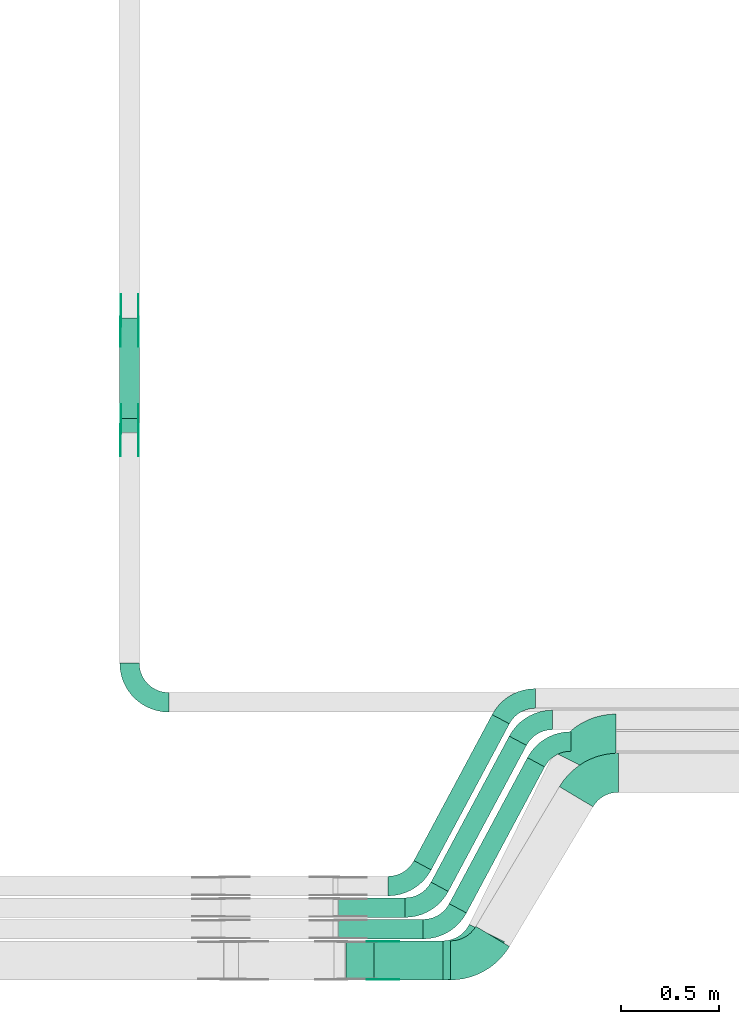
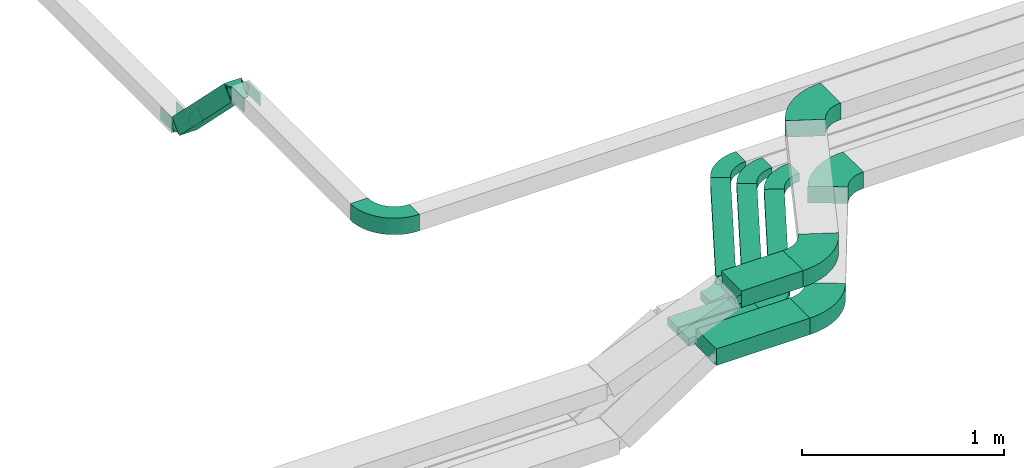
# One storey, part 8 of 25: 21 flow fittings, 8 flow segments.
"""IFC2X3 building model written with IfcOpenShell, lengths in millimetres."""

from ifc_helpers import new_model, entity, si_unit, converted_unit, derived_unit, direction, frame, frame_2d, origin, origin_2d_with_axis, place, context, subcontext, project, spatial, polyline, circle_curve, parameter, trimmed, segment, composite_curve, rectangle, outline, extrude, source, transform, mapped, material, type_object, type_shapes, element, save


model = new_model("IFC2X3")

# Units and contexts
model_context = context("Model", 3, precision=0.01, world=origin(), true_north=direction((6.12303176911189e-17, 1.0)))
body_context = subcontext(model_context, "Body", "Model", "MODEL_VIEW")
ifc_project = project(units=[si_unit("LENGTHUNIT", "METRE", prefix="MILLI"), si_unit("AREAUNIT", "SQUARE_METRE"), si_unit("VOLUMEUNIT", "CUBIC_METRE"), converted_unit("PLANEANGLEUNIT", "DEGREE", entity("IfcRatioMeasure", 0.0174532925199433), si_unit("PLANEANGLEUNIT", "RADIAN"), dimensions=[0, 0, 0, 0, 0, 0, 0]), si_unit("MASSUNIT", "GRAM", prefix="KILO"), derived_unit("MASSDENSITYUNIT", [(si_unit("MASSUNIT", "GRAM", prefix="KILO"), 1), (si_unit("LENGTHUNIT", "METRE"), -3)]), derived_unit("MOMENTOFINERTIAUNIT", [(si_unit("LENGTHUNIT", "METRE"), 4)]), si_unit("TIMEUNIT", "SECOND"), si_unit("FREQUENCYUNIT", "HERTZ"), si_unit("THERMODYNAMICTEMPERATUREUNIT", "DEGREE_CELSIUS"), derived_unit("THERMALTRANSMITTANCEUNIT", [(si_unit("MASSUNIT", "GRAM", prefix="KILO"), 1), (si_unit("THERMODYNAMICTEMPERATUREUNIT", "KELVIN"), -1), (si_unit("TIMEUNIT", "SECOND"), -3)]), derived_unit("VOLUMETRICFLOWRATEUNIT", [(si_unit("LENGTHUNIT", "METRE"), 3), (si_unit("TIMEUNIT", "SECOND"), -1)]), derived_unit("MASSFLOWRATEUNIT", [(si_unit("MASSUNIT", "GRAM", prefix="KILO"), 1), (si_unit("TIMEUNIT", "SECOND"), -1)]), derived_unit("ROTATIONALFREQUENCYUNIT", [(si_unit("TIMEUNIT", "SECOND"), -1)]), si_unit("ELECTRICCURRENTUNIT", "AMPERE"), si_unit("ELECTRICVOLTAGEUNIT", "VOLT"), si_unit("POWERUNIT", "WATT"), si_unit("FORCEUNIT", "NEWTON", prefix="KILO"), si_unit("ILLUMINANCEUNIT", "LUX"), si_unit("LUMINOUSFLUXUNIT", "LUMEN"), si_unit("LUMINOUSINTENSITYUNIT", "CANDELA"), derived_unit("USERDEFINED", [(si_unit("MASSUNIT", "GRAM", prefix="KILO"), -1), (si_unit("LENGTHUNIT", "METRE"), -2), (si_unit("TIMEUNIT", "SECOND"), 3), (si_unit("LUMINOUSFLUXUNIT", "LUMEN"), 1)]), derived_unit("LINEARVELOCITYUNIT", [(si_unit("LENGTHUNIT", "METRE"), 1), (si_unit("TIMEUNIT", "SECOND"), -1)]), si_unit("PRESSUREUNIT", "PASCAL"), derived_unit("USERDEFINED", [(si_unit("LENGTHUNIT", "METRE"), -2), (si_unit("MASSUNIT", "GRAM", prefix="KILO"), 1), (si_unit("TIMEUNIT", "SECOND"), -2)]), derived_unit("LINEARFORCEUNIT", [(si_unit("MASSUNIT", "GRAM", prefix="KILO"), 1), (si_unit("LENGTHUNIT", "METRE"), 1), (si_unit("TIMEUNIT", "SECOND"), -2), (si_unit("LENGTHUNIT", "METRE"), -1)]), derived_unit("PLANARFORCEUNIT", [(si_unit("MASSUNIT", "GRAM", prefix="KILO"), 1), (si_unit("LENGTHUNIT", "METRE"), 1), (si_unit("TIMEUNIT", "SECOND"), -2), (si_unit("LENGTHUNIT", "METRE"), -2)])], contexts=[model_context])

# Site, building, storey
site_placement = place(None, frame((0.0, -0.00077364408347762, 0.0)))
site = spatial("IfcSite", under=ifc_project, at=site_placement, CompositionType="ELEMENT")
building_placement = place(site_placement, origin())
building = spatial("IfcBuilding", under=site, at=building_placement, CompositionType="ELEMENT")
storey_placement = place(building_placement, frame((0.0, 0.0, 24000.0)))
storey = spatial("IfcBuildingStorey", under=building, at=storey_placement, CompositionType="ELEMENT", Elevation=24000.0)

# Flow segments
cable_carrier_segment_type = type_object("IfcCableCarrierSegmentType", PredefinedType="CABLETRAYSEGMENT")
flow_segment_1_placement = place(storey_placement, frame((41375.1084711671, 2908.92684314399, 3001.16800153785)))
element("IfcFlowSegment", 1, at=flow_segment_1_placement, inside=storey, type_object=cable_carrier_segment_type, context=body_context, shape_type="SweptSolid", body=[
    extrude(rectangle(XDim=100.000000000003, YDim=99.9999999999946, at=frame_2d((0.0, 1.95399252334028e-13), x_axis=(0.0, 1.0))), frame((50.0, 549.539047584719, 35.3553390593286), z_axis=(0.0, -0.70710678118655, 0.707106781186545), x_axis=(1.0, 0.0, 0.0)), (0.0, 0.0, 1.0), 727.16557414792),
])
flow_segment_2_placement = place(storey_placement, frame((42494.4226783687, 429.999226355384, 3217.23038971969)))
element("IfcFlowSegment", 2, at=flow_segment_2_placement, inside=storey, type_object=cable_carrier_segment_type, context=body_context, shape_type="SweptSolid", body=[
    extrude(rectangle(XDim=338.636913368324, YDim=100.0, at=frame_2d((4.33431068813661e-12, 0.0), x_axis=(1.0, 0.0))), frame((169.318456684166, 50.0, 0.0)), (0.0, 0.0, 1.0), 49.9999999999973),
])
flow_segment_3_placement = place(storey_placement, frame((42494.4226783688, 319.99922635538, 3217.23038971969)))
element("IfcFlowSegment", 3, at=flow_segment_3_placement, inside=storey, type_object=cable_carrier_segment_type, context=body_context, shape_type="SweptSolid", body=[
    extrude(rectangle(XDim=431.613954254771, YDim=100.0, at=origin_2d_with_axis()), frame((215.806977127385, 50.0, 0.0)), (0.0, 0.0, 1.0), 49.9999999999973),
])
flow_segment_4_placement = place(storey_placement, frame((42530.7101257599, 109.999226355385, 3217.23038971969)))
element("IfcFlowSegment", 4, at=flow_segment_4_placement, inside=storey, type_object=cable_carrier_segment_type, context=body_context, shape_type="SweptSolid", body=[
    extrude(rectangle(XDim=534.96469272526, YDim=200.0, at=frame_2d((-4.34852154285181e-12, 1.4210854715202e-14), x_axis=(1.0, 0.0))), frame((267.482346362634, 100.0, 0.0)), (0.0, 0.0, 1.0), 100.000000000003),
])
flow_segment_5_placement = place(storey_placement, frame((42674.3607845514, 109.999226355386, 3517.23038971969)))
element("IfcFlowSegment", 5, at=flow_segment_5_placement, inside=storey, type_object=cable_carrier_segment_type, context=body_context, shape_type="SweptSolid", body=[
    extrude(rectangle(XDim=352.353240473433, YDim=200.0, at=frame_2d((4.32009983342141e-12, 0.0), x_axis=(1.0, 0.0))), frame((176.176620236721, 100.0, 0.0)), (0.0, 0.0, 1.0), 100.000000000008),
])
flow_segment_6_placement = place(storey_placement, frame((42879.3654103889, 672.879058228402, 3217.23038971969)))
element("IfcFlowSegment", 6, at=flow_segment_6_placement, inside=storey, type_object=cable_carrier_segment_type, context=body_context, shape_type="SweptSolid", body=[
    extrude(rectangle(XDim=847.024364265398, YDim=99.9999999999933, at=frame_2d((-1.96109795069788e-12, 3.88311605092895e-12), x_axis=(1.0, 0.0))), frame((243.980475039275, 396.966478520281, 0.0), z_axis=(0.0, 0.0, 1.0), x_axis=(-0.472007051598709, -0.881594772693835, 0.0)), (0.0, 0.0, 1.0), 49.9999999999973),
])
flow_segment_7_placement = place(storey_placement, frame((42966.7708146927, 562.8790582284, 3217.23038971969)))
element("IfcFlowSegment", 7, at=flow_segment_7_placement, inside=storey, type_object=cable_carrier_segment_type, context=body_context, shape_type="SweptSolid", body=[
    extrude(rectangle(XDim=847.024364265391, YDim=99.9999999999915, at=origin_2d_with_axis()), frame((243.980475039266, 396.966478520282, 0.0), z_axis=(0.0, 0.0, 1.0), x_axis=(-0.472007051598681, -0.881594772693849, 0.0)), (0.0, 0.0, 1.0), 49.9999999999973),
])
flow_segment_8_placement = place(storey_placement, frame((43059.7478555792, 452.879058228397, 3217.23038971969)))
element("IfcFlowSegment", 8, at=flow_segment_8_placement, inside=storey, type_object=cable_carrier_segment_type, context=body_context, shape_type="SweptSolid", body=[
    extrude(rectangle(XDim=847.024364265398, YDim=99.9999999999913, at=origin_2d_with_axis()), frame((243.980475039266, 396.966478520285, 0.0), z_axis=(0.0, 0.0, 1.0), x_axis=(0.472007051598678, 0.881594772693851, 0.0)), (0.0, 0.0, 1.0), 49.9999999999973),
])

# Flow fittings
ifc_material_1 = material(Name="G")
cable_carrier_fitting_type_1 = type_object("IfcCableCarrierFittingType", PredefinedType="NOTDEFINED", material=ifc_material_1)
shared_shape_1 = source(origin(), body_context, "Body", "SweptSolid", [
    extrude(outline(composite_curve([segment(trimmed(circle_curve(frame_2d((-41.4651162790697, 0.0), x_axis=(1.0, 0.0)), 25.0), [parameter(90.0000000000007)], [parameter(270.0)], True, "PARAMETER"), True, "CONTINUOUS"), segment(polyline([(-41.4651162790697, -25.0), (-29.9651162790697, -25.0)]), True, "CONTINUOUS"), segment(polyline([(-29.9651162790697, -25.0), (-28.1046511627907, -38.5)]), True, "CONTINUOUS"), segment(polyline([(-28.1046511627907, -38.5), (99.5348837209303, -38.5)]), True, "CONTINUOUS"), segment(polyline([(99.5348837209303, -38.5), (99.5348837209303, 38.5)]), True, "CONTINUOUS"), segment(polyline([(99.5348837209303, 38.5), (-28.1046511627907, 38.5)]), True, "CONTINUOUS"), segment(polyline([(-28.1046511627907, 38.5), (-29.9651162790697, 25.0)]), True, "CONTINUOUS"), segment(polyline([(-29.9651162790697, 25.0), (-41.46511627907, 25.0)]), True, "CONTINUOUS")], self_intersect=False)), frame((41.4651162790697, 0.0, 0.0), z_axis=(0.0, 0.0, -1.0), x_axis=(1.0, 0.0, 0.0)), (0.0, 0.0, -1.0), 2.0),
])
type_shapes(cable_carrier_fitting_type_1, [shared_shape_1])
for number, where, z_axis, x_axis in (
    (9, (41379.648471157, 3474.98923132582, 3020.0), (-1.0, 0.0, 0.0), (0.0, -0.707106781186429, 0.707106781186666)),
    (10, (41470.5684711773, 2927.75884160621, 3567.23038971971), (1.0, 0.0, 0.0), (0.0, -1.0, 0.0)),
    (11, (42663.1689117257, 305.459226365548, 3567.23038971973), (0.0, 1.0, 0.0), (1.0, 0.0, 0.0)),
):
    element("IfcFlowFitting", number, at=place(storey_placement, frame(where, z_axis=z_axis, x_axis=x_axis)), inside=storey, type_object=cable_carrier_fitting_type_1, material=ifc_material_1, context=body_context, shape_type="MappedRepresentation", body=[
        mapped(shared_shape_1, transform((0.0, 0.0, 0.0), scale=1.0)),
    ])
cable_carrier_fitting_type_2 = type_object("IfcCableCarrierFittingType", PredefinedType="NOTDEFINED", material=ifc_material_1)
shared_shape_2 = source(origin(), body_context, "Body", "SweptSolid", [
    extrude(outline(composite_curve([segment(trimmed(circle_curve(frame_2d((-41.4651162790697, 0.0), x_axis=(1.0, 0.0)), 25.0), [parameter(90.0000000000007)], [parameter(270.0)], True, "PARAMETER"), True, "CONTINUOUS"), segment(polyline([(-41.4651162790697, -25.0), (-29.9651162790697, -25.0)]), True, "CONTINUOUS"), segment(polyline([(-29.9651162790697, -25.0), (-28.1046511627907, -38.5)]), True, "CONTINUOUS"), segment(polyline([(-28.1046511627907, -38.5), (99.5348837209303, -38.5)]), True, "CONTINUOUS"), segment(polyline([(99.5348837209303, -38.5), (99.5348837209303, 38.5)]), True, "CONTINUOUS"), segment(polyline([(99.5348837209303, 38.5), (-28.1046511627907, 38.5)]), True, "CONTINUOUS"), segment(polyline([(-28.1046511627907, 38.5), (-29.9651162790697, 25.0)]), True, "CONTINUOUS"), segment(polyline([(-29.9651162790697, 25.0), (-41.46511627907, 25.0)]), True, "CONTINUOUS")], self_intersect=False)), frame((41.4651162790697, 0.0, 0.0)), (0.0, 0.0, 1.0), 2.0),
])
type_shapes(cable_carrier_fitting_type_2, [shared_shape_2])
for number, where, z_axis, x_axis in (
    (12, (41470.5684711773, 3474.98923132582, 3020.0), (1.0, 0.0, 0.0), (0.0, -0.707106781186429, 0.707106781186666)),
    (13, (41379.648471157, 2927.75884160621, 3567.23038971971), (-1.0, 0.0, 0.0), (0.0, -1.0, 0.0)),
    (14, (42663.1689117257, 114.53922634523, 3567.23038971973), (0.0, -1.0, 0.0), (1.0, 0.0, 0.0)),
):
    element("IfcFlowFitting", number, at=place(storey_placement, frame(where, z_axis=z_axis, x_axis=x_axis)), inside=storey, type_object=cable_carrier_fitting_type_2, material=ifc_material_1, context=body_context, shape_type="MappedRepresentation", body=[
        mapped(shared_shape_2, transform((0.0, 0.0, 0.0), scale=1.0)),
    ])
cable_carrier_fitting_type_3 = type_object("IfcCableCarrierFittingType", PredefinedType="NOTDEFINED", material=ifc_material_1)
shared_shape_3 = source(origin(), body_context, "Body", "SweptSolid", [
    extrude(outline(composite_curve([segment(trimmed(circle_curve(frame_2d((-41.4651162790697, 0.0), x_axis=(1.0, 0.0)), 25.0), [parameter(90.0000000000007)], [parameter(270.0)], True, "PARAMETER"), True, "CONTINUOUS"), segment(polyline([(-41.4651162790697, -25.0), (-29.9651162790697, -25.0)]), True, "CONTINUOUS"), segment(polyline([(-29.9651162790697, -25.0), (-28.1046511627907, -38.5)]), True, "CONTINUOUS"), segment(polyline([(-28.1046511627907, -38.5), (99.5348837209303, -38.5)]), True, "CONTINUOUS"), segment(polyline([(99.5348837209303, -38.5), (99.5348837209303, 38.5)]), True, "CONTINUOUS"), segment(polyline([(99.5348837209303, 38.5), (-28.1046511627907, 38.5)]), True, "CONTINUOUS"), segment(polyline([(-28.1046511627907, 38.5), (-29.9651162790697, 25.0)]), True, "CONTINUOUS"), segment(polyline([(-29.9651162790697, 25.0), (-41.46511627907, 25.0)]), True, "CONTINUOUS")], self_intersect=False)), frame((41.4651162790697, 0.0, 0.0), z_axis=(0.0, 0.0, -1.0), x_axis=(1.0, 0.0, 0.0)), (0.0, 0.0, -1.0), 2.0),
])
type_shapes(cable_carrier_fitting_type_3, [shared_shape_3])
for number, where, z_axis, x_axis in (
    (15, (41468.5684711773, 3474.98923132582, 3020.0), (1.0, 0.0, 0.0), (0.0, 1.0, 0.0)),
    (16, (41381.648471157, 2927.75884160621, 3567.23038971971), (-1.0, 0.0, 0.0), (0.0, 0.707106781186541, -0.707106781186554)),
):
    element("IfcFlowFitting", number, at=place(storey_placement, frame(where, z_axis=z_axis, x_axis=x_axis)), inside=storey, type_object=cable_carrier_fitting_type_3, material=ifc_material_1, context=body_context, shape_type="MappedRepresentation", body=[
        mapped(shared_shape_3, transform((0.0, 0.0, 0.0), scale=1.0)),
    ])
cable_carrier_fitting_type_4 = type_object("IfcCableCarrierFittingType", PredefinedType="NOTDEFINED", material=ifc_material_1)
shared_shape_4 = source(origin(), body_context, "Body", "SweptSolid", [
    extrude(outline(composite_curve([segment(trimmed(circle_curve(frame_2d((-41.4651162790697, 0.0), x_axis=(1.0, 0.0)), 25.0), [parameter(90.0000000000007)], [parameter(270.0)], True, "PARAMETER"), True, "CONTINUOUS"), segment(polyline([(-41.4651162790697, -25.0), (-29.9651162790697, -25.0)]), True, "CONTINUOUS"), segment(polyline([(-29.9651162790697, -25.0), (-28.1046511627907, -38.5)]), True, "CONTINUOUS"), segment(polyline([(-28.1046511627907, -38.5), (99.5348837209303, -38.5)]), True, "CONTINUOUS"), segment(polyline([(99.5348837209303, -38.5), (99.5348837209303, 38.5)]), True, "CONTINUOUS"), segment(polyline([(99.5348837209303, 38.5), (-28.1046511627907, 38.5)]), True, "CONTINUOUS"), segment(polyline([(-28.1046511627907, 38.5), (-29.9651162790697, 25.0)]), True, "CONTINUOUS"), segment(polyline([(-29.9651162790697, 25.0), (-41.46511627907, 25.0)]), True, "CONTINUOUS")], self_intersect=False)), frame((41.4651162790697, 0.0, 0.0)), (0.0, 0.0, 1.0), 2.0),
])
type_shapes(cable_carrier_fitting_type_4, [shared_shape_4])
for number, where, z_axis, x_axis in (
    (17, (41381.648471157, 3474.98923132582, 3020.0), (-1.0, 0.0, 0.0), (0.0, 1.0, 0.0)),
    (18, (41468.5684711773, 2927.75884160621, 3567.23038971971), (1.0, 0.0, 0.0), (0.0, 0.707106781186541, -0.707106781186554)),
):
    element("IfcFlowFitting", number, at=place(storey_placement, frame(where, z_axis=z_axis, x_axis=x_axis)), inside=storey, type_object=cable_carrier_fitting_type_4, material=ifc_material_1, context=body_context, shape_type="MappedRepresentation", body=[
        mapped(shared_shape_4, transform((0.0, 0.0, 0.0), scale=1.0)),
    ])
ifc_material_2 = material()
cable_carrier_fitting_type_5 = type_object("IfcCableCarrierFittingType", Name="470_DKC_S5_Variable Angle Elbow 0-45:-", PredefinedType="NOTDEFINED", material=ifc_material_2)
shared_shape_5 = source(origin(), body_context, "Body", "SweptSolid", [
    extrude(outline(composite_curve([segment(polyline([(-100.749999999999, -150.250000000001), (-99.7499999999981, -150.250000000001)]), True, "CONTINUOUS"), segment(trimmed(circle_curve(frame_2d((-99.7500000000006, 99.7499999999987), x_axis=(0.0, -1.0)), 250.0), [parameter(0.0)], [parameter(90.0000000000001)], True, "PARAMETER"), True, "CONTINUOUS"), segment(polyline([(150.249999999999, 99.7500000000013), (150.249999999999, 100.750000000001)]), True, "CONTINUOUS"), segment(polyline([(150.249999999999, 100.750000000001), (50.2499999999992, 100.750000000001)]), True, "CONTINUOUS"), segment(polyline([(50.2499999999992, 100.750000000001), (50.2499999999992, 99.7500000000002)]), True, "CONTINUOUS"), segment(trimmed(circle_curve(frame_2d((-99.7500000000006, 99.7499999999987), x_axis=(0.0, -1.0)), 150.0), [parameter(0.0)], [parameter(90.0000000000001)], True, "PARAMETER"), False, "CONTINUOUS"), segment(polyline([(-99.7499999999989, -50.2500000000011), (-100.75, -50.2500000000011)]), True, "CONTINUOUS"), segment(polyline([(-100.75, -50.2500000000011), (-100.749999999999, -150.250000000001)]), True, "CONTINUOUS")], self_intersect=False)), frame((-100.249999999991, 100.249999999992, -50.0)), (0.0, 0.0, 1.0), 100.0),
])
type_shapes(cable_carrier_fitting_type_5, [shared_shape_5])
flow_fitting_1_placement = place(storey_placement, frame((41425.1084711671, 1529.691847142, 3567.23038971969), z_axis=(0.0, 0.0, 1.0), x_axis=(0.0, -1.0, 0.0)))
element("IfcFlowFitting", 19, at=flow_fitting_1_placement, inside=storey, type_object=cable_carrier_fitting_type_5, material=ifc_material_2, Name="470_DKC_S5_Variable Angle Elbow 0-45:-", ObjectType="470_DKC_S5_Variable Angle Elbow 0-45:-", context=body_context, shape_type="MappedRepresentation", body=[
    mapped(shared_shape_5, transform((0.0, 0.0, 0.0), scale=1.0)),
])
cable_carrier_fitting_type_6 = type_object("IfcCableCarrierFittingType", Name="470_DKC_S5_Variable Angle Elbow 0-45:-", PredefinedType="NOTDEFINED", material=ifc_material_2)
shared_shape_6 = source(origin(), body_context, "Body", "SweptSolid", [
    extrude(outline(composite_curve([segment(polyline([(-89.0274790322828, -103.019693533301), (-88.0274790322816, -103.019693533301)]), True, "CONTINUOUS"), segment(trimmed(circle_curve(frame_2d((-88.0274790322819, 146.980306466699), x_axis=(0.0, -1.0)), 250.0), [parameter(0.0)], [parameter(61.8353423405045)], True, "PARAMETER"), True, "CONTINUOUS"), segment(polyline([(132.371214141174, 28.9785435670171), (132.843221192772, 29.8601383397107)]), True, "CONTINUOUS"), segment(polyline([(132.843221192772, 29.8601383397107), (44.6837439233904, 77.0608434995841)]), True, "CONTINUOUS"), segment(polyline([(44.6837439233904, 77.0608434995841), (44.2117368717915, 76.1792487268899)]), True, "CONTINUOUS"), segment(trimmed(circle_curve(frame_2d((-88.0274790322819, 146.980306466699), x_axis=(0.0, -1.0)), 150.0), [parameter(0.0)], [parameter(61.8353423405045)], True, "PARAMETER"), False, "CONTINUOUS"), segment(polyline([(-88.0274790322816, -3.01969353330072), (-89.0274790322828, -3.01969353330072)]), True, "CONTINUOUS"), segment(polyline([(-89.0274790322828, -3.01969353330072), (-89.0274790322828, -103.019693533301)]), True, "CONTINUOUS")], self_intersect=False)), frame((-31.7538456205128, 53.0196935332925, -25.0)), (0.0, 0.0, 1.0), 49.9999999999998),
])
type_shapes(cable_carrier_fitting_type_6, [shared_shape_6])
for number, where, name in (
    (20, (42866.435512086, 589.999226355405, 3242.23038971968), "470_DKC_S5_Variable Angle Elbow 0-45:-"),
    (21, (42953.8409163899, 479.999226355401, 3242.23038971968), "470_DKC_S5_Variable Angle Elbow 0-45:-"),
    (22, (43046.8179572763, 369.999226355397, 3242.23038971968), "470_DKC_S5_Variable Angle Elbow 0-45:-"),
):
    element("IfcFlowFitting", number, at=place(storey_placement, frame(where)), inside=storey, type_object=cable_carrier_fitting_type_6, material=ifc_material_2, Name=name, ObjectType="470_DKC_S5_Variable Angle Elbow 0-45:-", context=body_context, shape_type="MappedRepresentation", body=[
        mapped(shared_shape_6, transform((0.0, 0.0, 0.0), scale=1.0)),
    ])
for number, where, z_axis, x_axis, name in (
    (23, (43560.6387039606, 1329.69184714197, 3242.23038971968), (0.0, 0.0, 1.0), (-1.0, 0.0, 0.0), "470_DKC_S5_Variable Angle Elbow 0-45:-"),
    (24, (43467.6616630741, 1439.69184714197, 3242.23038971968), (0.0, 0.0, 1.0), (-1.0, 0.0, 0.0), "470_DKC_S5_Variable Angle Elbow 0-45:-"),
    (25, (43380.2562587703, 1549.69184714197, 3242.23038971968), (0.0, 0.0, 1.0), (-1.0, 0.0, 0.0), "470_DKC_S5_Variable Angle Elbow 0-45:-"),
):
    element("IfcFlowFitting", number, at=place(storey_placement, frame(where, z_axis=z_axis, x_axis=x_axis)), inside=storey, type_object=cable_carrier_fitting_type_6, material=ifc_material_2, Name=name, ObjectType="470_DKC_S5_Variable Angle Elbow 0-45:-", context=body_context, shape_type="MappedRepresentation", body=[
        mapped(shared_shape_6, transform((0.0, 0.0, 0.0), scale=1.0)),
    ])
cable_carrier_fitting_type_7 = type_object("IfcCableCarrierFittingType", Name="470_DKC_S5_Variable Angle Elbow 0-45:-", PredefinedType="NOTDEFINED", material=ifc_material_2)
shared_shape_7 = source(origin(), body_context, "Body", "SweptSolid", [
    extrude(outline(composite_curve([segment(polyline([(-108.177372879361, -161.090516695572), (-107.177372879359, -161.090516695572)]), True, "CONTINUOUS"), segment(trimmed(circle_curve(frame_2d((-107.17737287936, 188.909483304428), x_axis=(0.0, -1.0)), 350.0), [parameter(0.0)], [parameter(59.1366247749536)], True, "PARAMETER"), True, "CONTINUOUS"), segment(polyline([(193.260176326146, 9.36205495361872), (193.773168978577, 10.220447951349)]), True, "CONTINUOUS"), segment(polyline([(193.773168978577, 10.220447951349), (22.0945694325735, 112.818978437525)]), True, "CONTINUOUS"), segment(polyline([(22.0945694325735, 112.818978437525), (21.5815767801427, 111.960585439795)]), True, "CONTINUOUS"), segment(trimmed(circle_curve(frame_2d((-107.17737287936, 188.909483304428), x_axis=(0.0, -1.0)), 150.0), [parameter(0.0)], [parameter(59.1366247749536)], True, "PARAMETER"), False, "CONTINUOUS"), segment(polyline([(-107.177372879359, 38.9094833044277), (-108.177372879361, 38.9094833044277)]), True, "CONTINUOUS"), segment(polyline([(-108.177372879361, 38.9094833044277), (-108.177372879361, -161.090516695572)]), True, "CONTINUOUS")], self_intersect=False)), frame((-34.659568025608, 61.0905166955641, -50.0)), (0.0, 0.0, 1.0), 100.0),
])
type_shapes(cable_carrier_fitting_type_7, [shared_shape_7])
flow_fitting_2_placement = place(storey_placement, frame((43782.0430723873, 1169.69184714197, 3267.23038971969), z_axis=(0.0, 0.0, 1.0), x_axis=(-1.0, 0.0, 0.0)))
element("IfcFlowFitting", 26, at=flow_fitting_2_placement, inside=storey, type_object=cable_carrier_fitting_type_7, material=ifc_material_2, Name="470_DKC_S5_Variable Angle Elbow 0-45:-", ObjectType="470_DKC_S5_Variable Angle Elbow 0-45:-", context=body_context, shape_type="MappedRepresentation", body=[
    mapped(shared_shape_7, transform((0.0, 0.0, 0.0), scale=1.0)),
])
flow_fitting_3_placement = place(storey_placement, frame((43208.5117593901, 209.999226355394, 3267.23038971969)))
element("IfcFlowFitting", 27, at=flow_fitting_3_placement, inside=storey, type_object=cable_carrier_fitting_type_7, material=ifc_material_2, Name="470_DKC_S5_Variable Angle Elbow 0-45:-", ObjectType="470_DKC_S5_Variable Angle Elbow 0-45:-", context=body_context, shape_type="MappedRepresentation", body=[
    mapped(shared_shape_7, transform((0.0, 0.0, 0.0), scale=1.0)),
])
cable_carrier_fitting_type_8 = type_object("IfcCableCarrierFittingType", Name="470_DKC_S5_Variable Angle Elbow 0-45:-", PredefinedType="NOTDEFINED", material=ifc_material_2)
shared_shape_8 = source(origin(), body_context, "Body", "SweptSolid", [
    extrude(outline(composite_curve([segment(polyline([(-112.968043679005, -169.934827950355), (-111.968043679004, -169.934827950355)]), True, "CONTINUOUS"), segment(trimmed(circle_curve(frame_2d((-111.968043679005, 180.065172049645), x_axis=(0.0, -1.0)), 350.0), [parameter(0.0)], [parameter(63.7483130924797)], True, "PARAMETER"), True, "CONTINUOUS"), segment(polyline([(201.932858055123, 25.2548885071707), (202.37517315096, 26.1517482264134)]), True, "CONTINUOUS"), segment(polyline([(202.37517315096, 26.1517482264133), (23.0032293028847, 114.614767393537)]), True, "CONTINUOUS"), segment(polyline([(23.0032293028847, 114.614767393537), (22.5609142070502, 113.717907674299)]), True, "CONTINUOUS"), segment(trimmed(circle_curve(frame_2d((-111.968043679005, 180.065172049645), x_axis=(0.0, -1.0)), 150.0), [parameter(0.0)], [parameter(63.7483130924797)], True, "PARAMETER"), False, "CONTINUOUS"), segment(polyline([(-111.968043679004, 30.0651720496448), (-112.968043679005, 30.0651720496448)]), True, "CONTINUOUS"), segment(polyline([(-112.968043679005, 30.0651720496448), (-112.968043679005, -169.934827950355)]), True, "CONTINUOUS")], self_intersect=False)), frame((-43.4868430218609, 69.934827950347, -50.0)), (0.0, 0.0, 1.0), 100.0),
])
type_shapes(cable_carrier_fitting_type_8, [shared_shape_8])
flow_fitting_4_placement = place(storey_placement, frame((43183.1689117257, 209.999226355394, 3567.23038971969)))
element("IfcFlowFitting", 28, at=flow_fitting_4_placement, inside=storey, type_object=cable_carrier_fitting_type_8, material=ifc_material_2, Name="470_DKC_S5_Variable Angle Elbow 0-45:-", ObjectType="470_DKC_S5_Variable Angle Elbow 0-45:-", context=body_context, shape_type="MappedRepresentation", body=[
    mapped(shared_shape_8, transform((0.0, 0.0, 0.0), scale=1.0)),
])
flow_fitting_5_placement = place(storey_placement, frame((43755.1084711671, 1369.69184714199, 3567.23038971969), z_axis=(0.0, 0.0, 1.0), x_axis=(-1.0, 0.0, 0.0)))
element("IfcFlowFitting", 29, at=flow_fitting_5_placement, inside=storey, type_object=cable_carrier_fitting_type_8, material=ifc_material_2, Name="470_DKC_S5_Variable Angle Elbow 0-45:-", ObjectType="470_DKC_S5_Variable Angle Elbow 0-45:-", context=body_context, shape_type="MappedRepresentation", body=[
    mapped(shared_shape_8, transform((0.0, 0.0, 0.0), scale=1.0)),
])

save(model, "model.ifc")
